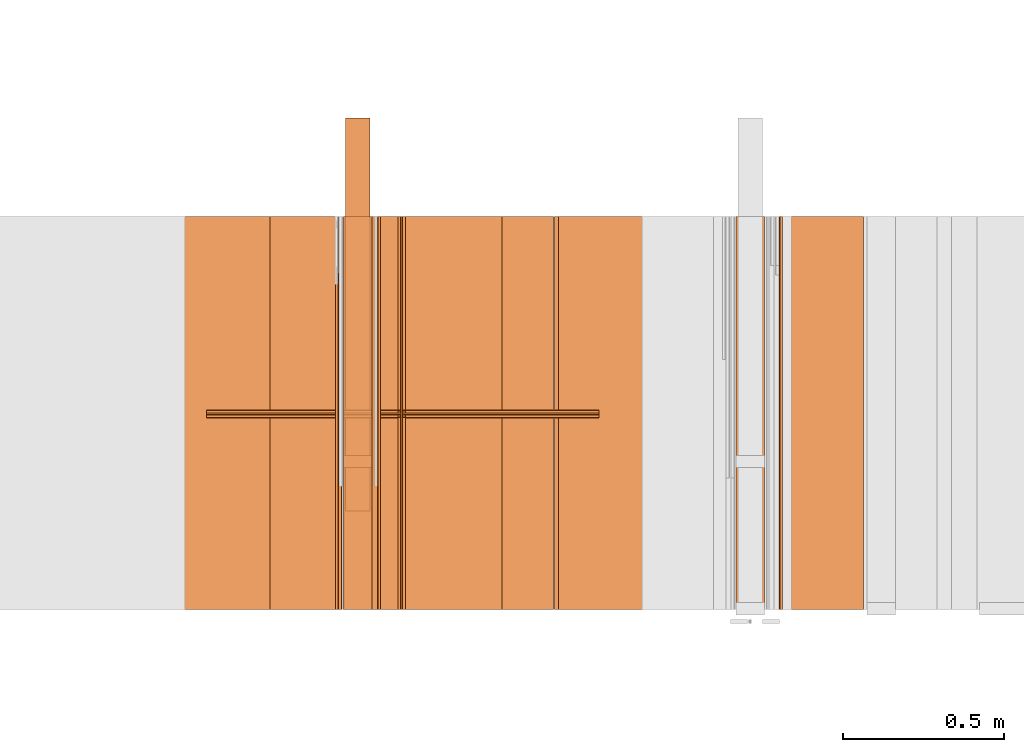
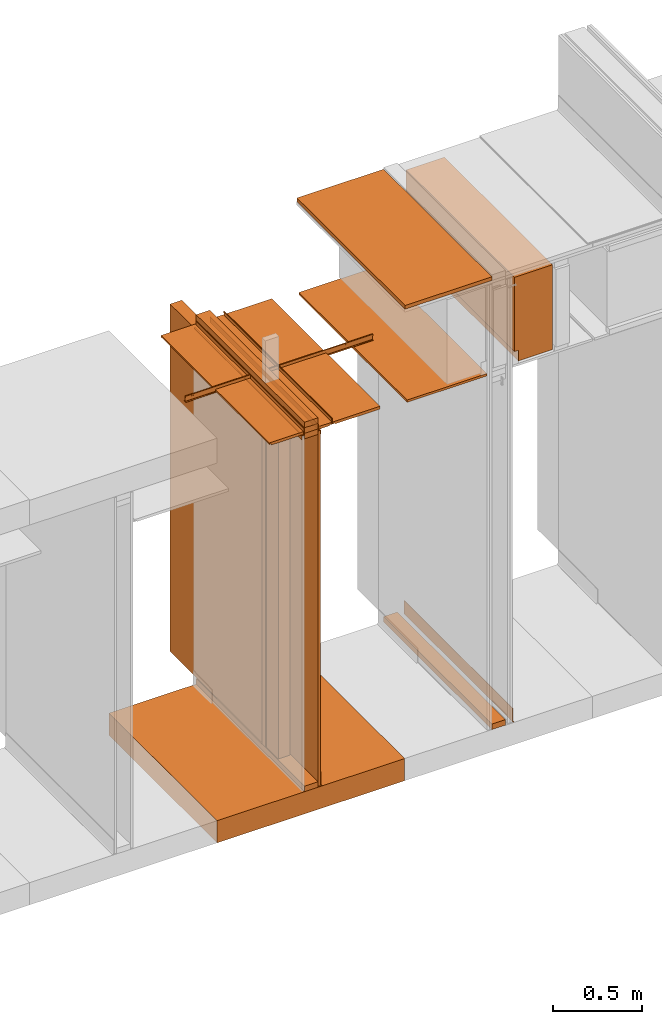
# One storey, part 34 of 64: 24 proxies.
"""IFC4 building model written with IfcOpenShell, lengths in feet."""

import ifcopenshell
import ifcopenshell.guid

model = None  # the IFC model being written
_history = None  # IfcOwnerHistory: only IFC2X3 demands one
_inside = {}  # id of a spatial element -> (the spatial element, [elements in it])
_under = {}  # id of a project, library or spatial element -> (it, [spatial elements below it])
_declared = {}  # id of a project -> (the project, [libraries it declares])
_typed = {}  # id of a type object -> (the type object, [elements of that type])
_made_of = {}  # id of a material, layer set ... -> (it, [elements and type objects made of it])


def new_model(schema):
    """Start an empty IFC model of exactly this schema.

    Asked for "IFC4X3", IfcOpenShell would pick the latest addendum, in which some entities
    have other attributes; the version numbers below select the first issue.
    IFC2X3 requires an IfcOwnerHistory on every rooted entity: one is made here for all.
    """
    global model, _history
    if schema == "IFC4X3":
        model = ifcopenshell.file(schema_version=(4, 3, 0, 0))
    else:
        model = ifcopenshell.file(schema=schema)
    _inside.clear()
    _under.clear()
    _declared.clear()
    _typed.clear()
    _made_of.clear()
    _history = None
    if model.schema == "IFC2X3":
        org = make("IfcOrganization", Name="unknown")
        user = make(
            "IfcPersonAndOrganization",
            ThePerson=make("IfcPerson", FamilyName="unknown"),
            TheOrganization=org,
        )
        app = make(
            "IfcApplication",
            ApplicationDeveloper=org,
            Version="unknown",
            ApplicationFullName="unknown",
            ApplicationIdentifier="unknown",
        )
        _history = make(
            "IfcOwnerHistory",
            OwningUser=user,
            OwningApplication=app,
            ChangeAction="ADDED",
            CreationDate=0,
        )
    return model


def make(cls, **values):
    """One entity of the class cls with the attributes given. An attribute that is None is left unset."""
    return model.create_entity(
        cls, **{name: value for name, value in values.items() if value is not None}
    )


def entity(cls, *values):
    """Any entity or typed value of the class cls, its attributes in the order of the schema. None: left unset."""
    e = model.create_entity(cls)
    for i, value in enumerate(values):
        if value is not None:
            e[i] = value
    return e


def rooted(cls, **values):
    """An entity with a GlobalId (a new one), such as an element, a storey or a relation."""
    return make(cls, GlobalId=ifcopenshell.guid.new(), OwnerHistory=_history, **values)


def si_unit(unit_type, name, prefix=None):
    """IfcSIUnit, for example si_unit("LENGTHUNIT", "METRE", prefix="MILLI")."""
    return make("IfcSIUnit", UnitType=unit_type, Prefix=prefix, Name=name)


def converted_unit(unit_type, name, factor, base, dimensions=None, offset=None):
    """IfcConversionBasedUnit, such as the inch: factor (a typed value) times the base unit."""
    return make(
        "IfcConversionBasedUnit"
        if offset is None
        else "IfcConversionBasedUnitWithOffset",
        ConversionOffset=offset,
        Dimensions=None
        if dimensions is None
        else entity("IfcDimensionalExponents", *dimensions),
        UnitType=unit_type,
        Name=name,
        ConversionFactor=make(
            "IfcMeasureWithUnit", ValueComponent=factor, UnitComponent=base
        ),
    )


def assignment(units):
    """IfcUnitAssignment: the units of a project."""
    return None if units is None else make("IfcUnitAssignment", Units=units)


def point(xyz):
    """IfcCartesianPoint."""
    return None if xyz is None else make("IfcCartesianPoint", Coordinates=xyz)


def direction(xyz):
    """IfcDirection."""
    return None if xyz is None else make("IfcDirection", DirectionRatios=xyz)


def frame(location, z_axis=None, x_axis=None):
    """IfcAxis2Placement3D, a coordinate frame: its origin and axes. An axis left out is left unset."""
    return make(
        "IfcAxis2Placement3D",
        Location=point(location),
        Axis=direction(z_axis),
        RefDirection=direction(x_axis),
    )


def frame_2d(location, x_axis=None):
    """IfcAxis2Placement2D, a coordinate frame in the plane: its origin and x axis."""
    return make(
        "IfcAxis2Placement2D", Location=point(location), RefDirection=direction(x_axis)
    )


def origin_with_axes():
    """The frame at (0, 0, 0) with the z axis (0, 0, 1) and the x axis (1, 0, 0) written out."""
    return frame((0.0, 0.0, 0.0), z_axis=(0.0, 0.0, 1.0), x_axis=(1.0, 0.0, 0.0))


def origin_2d_with_axis():
    """The frame at (0, 0) in the plane with the x axis (1, 0) written out."""
    return frame_2d((0.0, 0.0), x_axis=(1.0, 0.0))


def place(relative_to, where):
    """IfcLocalPlacement: puts the frame where relative to a parent placement (None: the world)."""
    return make(
        "IfcLocalPlacement", PlacementRelTo=relative_to, RelativePlacement=where
    )


def context(
    kind, dimensions, precision=None, world=None, true_north=None, identifier=None
):
    """IfcGeometricRepresentationContext, for example the 3D "Model" context."""
    return make(
        "IfcGeometricRepresentationContext",
        ContextIdentifier=identifier,
        ContextType=kind,
        CoordinateSpaceDimension=dimensions,
        Precision=precision,
        WorldCoordinateSystem=world,
        TrueNorth=true_north,
    )


def subcontext(parent, identifier, kind, view, scale=None):
    """IfcGeometricRepresentationSubContext, for example "Body" below "Model"."""
    return make(
        "IfcGeometricRepresentationSubContext",
        ContextIdentifier=identifier,
        ContextType=kind,
        ParentContext=parent,
        TargetScale=scale,
        TargetView=view,
    )


def project(units=None, contexts=None):
    """IfcProject with its units and contexts."""
    return rooted(
        "IfcProject",
        Name="project",
        RepresentationContexts=contexts,
        UnitsInContext=assignment(units),
    )


def spatial(cls, under=None, at=None, **own):
    """A site, building, storey or space (cls), placed at a placement, below another one or the project."""
    s = rooted(cls, ObjectPlacement=at, **own)
    if under is not None:
        _under.setdefault(under.id(), (under, []))[1].append(s)
    return s


def polyline(points):
    """IfcPolyline through the points."""
    return make("IfcPolyline", Points=[point(p) for p in points])


def point_list(points):
    """IfcCartesianPointList2D or 3D."""
    cls = (
        "IfcCartesianPointList2D" if len(points[0]) == 2 else "IfcCartesianPointList3D"
    )
    return make(cls, CoordList=points)


def line(*indices):
    """IfcLineIndex: a straight run through numbered points of an indexed curve."""
    return model.create_entity("IfcLineIndex", indices)


def indexed_curve(points, segments=None, self_intersect=None):
    """IfcIndexedPolyCurve: lines and arcs through numbered points (the first is 1)."""
    return make(
        "IfcIndexedPolyCurve",
        Points=point_list(points),
        Segments=segments,
        SelfIntersect=self_intersect,
    )


def outline(outer, holes=None, kind="AREA"):
    """IfcArbitraryClosedProfileDef: a profile drawn as a closed curve; with holes, ...WithVoids."""
    if holes is None:
        return make("IfcArbitraryClosedProfileDef", ProfileType=kind, OuterCurve=outer)
    return make(
        "IfcArbitraryProfileDefWithVoids",
        ProfileType=kind,
        OuterCurve=outer,
        InnerCurves=holes,
    )


def extrude(swept, where, along, depth):
    """IfcExtrudedAreaSolid: the profile swept, set in the frame where, extruded along a direction by depth."""
    return make(
        "IfcExtrudedAreaSolid",
        SweptArea=swept,
        Position=where,
        ExtrudedDirection=direction(along),
        Depth=depth,
    )


def shape(context_of_items, identifier, shape_type, items):
    """IfcShapeRepresentation: the items that make up one representation, for example the "Body"."""
    return make(
        "IfcShapeRepresentation",
        ContextOfItems=context_of_items,
        RepresentationIdentifier=identifier,
        RepresentationType=shape_type,
        Items=items,
    )


def material(Name=None, Category=None):
    """IfcMaterial."""
    return make("IfcMaterial", Name=Name, Category=Category)


def made_of(thing, what):
    """Note that an element or type object is made of a material, layer set ...; save() writes the relation."""
    if what is not None:
        _made_of.setdefault(what.id(), (what, []))[1].append(thing)
    return thing


def element(
    cls,
    number,
    at=None,
    inside=None,
    cuts=None,
    type_object=None,
    material=None,
    context=None,
    identifier="Body",
    shape_type=None,
    held_by="IfcProductDefinitionShape",
    body=None,
    shapes=None,
    **own,
):
    """One element of the class cls, such as IfcWall. Its Tag is "e" and its number.

    at: its placement. inside: the storey or other place that contains it. cuts: it is an
    opening in that element (IfcRelVoidsElement). A single representation is given by context,
    identifier, shape_type and body (its items); several are given by shapes. held_by: the class
    of the entity that holds the representations. save() writes the other relations.
    """
    e = rooted(cls, Tag="e%d" % number, ObjectPlacement=at, **own)
    if body is not None:
        shapes = [shape(context, identifier, shape_type, body)]
    if shapes is not None:
        e.Representation = make(held_by, Representations=shapes)
    if inside is not None:
        _inside.setdefault(inside.id(), (inside, []))[1].append(e)
    if cuts is not None:
        rooted(
            "IfcRelVoidsElement", RelatingBuildingElement=cuts, RelatedOpeningElement=e
        )
    if type_object is not None:
        _typed.setdefault(type_object.id(), (type_object, []))[1].append(e)
    return made_of(e, material)


def aggregate(whole, parts):
    """IfcRelAggregates: a whole, such as a stair, and the parts it consists of."""
    return rooted("IfcRelAggregates", RelatingObject=whole, RelatedObjects=parts)


def save(model, path):
    """Write the relations noted so far, then the file.

    IfcRelAggregates (storeys below a building ...), IfcRelContainedInSpatialStructure (elements
    in a storey), IfcRelDefinesByType, IfcRelAssociatesMaterial and IfcRelDeclares: one each for
    every whole, place, type object, material and project.
    """
    for whole, parts in _under.values():
        aggregate(whole, parts)
    for where, things in _inside.values():
        rooted(
            "IfcRelContainedInSpatialStructure",
            RelatedElements=things,
            RelatingStructure=where,
        )
    for kind, things in _typed.values():
        rooted("IfcRelDefinesByType", RelatedObjects=things, RelatingType=kind)
    for what, things in _made_of.values():
        rooted("IfcRelAssociatesMaterial", RelatedObjects=things, RelatingMaterial=what)
    for by, libraries in _declared.values():
        rooted("IfcRelDeclares", RelatingContext=by, RelatedDefinitions=libraries)
    model.write(path)


model = new_model("IFC4")

# Units and contexts
model_context_1 = context("Model", 3, precision=1e-05, world=origin_with_axes())
plan_context = context("Plan", 2, precision=1e-05, world=origin_2d_with_axis())
model_context_2 = context("Model", 3, precision=1e-05, world=origin_with_axes())
context_of_model_1 = context(None, 3, precision=1e-05, world=origin_with_axes())
context_of_model_2 = context(None, 3, precision=1e-05, world=origin_with_axes())
body_context = subcontext(model_context_2, "Body", "Model", "MODEL_VIEW")
ifc_project = project(units=[converted_unit("PLANEANGLEUNIT", "degree", entity("IfcReal", 0.0174532925199433), si_unit("PLANEANGLEUNIT", "RADIAN"), dimensions=[0, 0, 0, 0, 0, 0, 0]), converted_unit("AREAUNIT", "square foot", entity("IfcReal", 0.09290304), si_unit("AREAUNIT", "SQUARE_METRE"), dimensions=[2, 0, 0, 0, 0, 0, 0]), converted_unit("LENGTHUNIT", "foot", entity("IfcReal", 0.3048), si_unit("LENGTHUNIT", "METRE"), dimensions=[1, 0, 0, 0, 0, 0, 0]), converted_unit("VOLUMEUNIT", "cubic foot", entity("IfcReal", 0.0283168467116885), si_unit("VOLUMEUNIT", "CUBIC_METRE"), dimensions=[3, 0, 0, 0, 0, 0, 0])], contexts=[model_context_1, plan_context, context_of_model_1, context_of_model_2])

# Site, building, storey
site_placement = place(None, origin_with_axes())
site = spatial("IfcSite", under=ifc_project, at=site_placement)
building_placement = place(site_placement, origin_with_axes())
building = spatial("IfcBuilding", under=site, at=building_placement, Name="Building")
storey_placement = place(building_placement, origin_with_axes())
storey = spatial("IfcBuildingStorey", under=building, at=storey_placement, Name="Storey")

# Proxies
proxy_1_placement = place(storey_placement, frame((1383.04162213183, 5.99999987860051, 0.0), z_axis=(4.37113882867379e-08, -0.999999999999999, -8.51092183247426e-15), x_axis=(1.94707183709394e-07, 0.0, 0.999999999999981)))
element("IfcBuildingElementProxy", 1, at=proxy_1_placement, inside=storey, Name="Generic Models 13:Generic Models 1", PredefinedType="COMPLEX", context=body_context, shape_type="SweptSolid", body=[
    extrude(outline(polyline([(-0.0625000007724355, -0.145833333098669), (0.0625000007724355, -0.145833333098669), (0.062500006883476, 0.145833333098669), (-0.0625000007724355, 0.145833333098669), (-0.0625000007724355, -0.145833333098669)])), frame((0.0625000313276381, -0.145833320876588, -4.08491298529716e-07), z_axis=(-1.6389038902582e-14, 1.19209246918217e-07, -1.0), x_axis=(1.0, 1.94707183709397e-07, 0.0)), (5.40078315403036e-10, -5.71617336797559e-11, -1.0), 4.00000000752362),
])
proxy_2_placement = place(storey_placement, frame((1379.04530122211, 5.99999987860051, 7.9530516634463), z_axis=(4.37113882867379e-08, -0.999999999999999, -8.51092183247426e-15), x_axis=(1.94707183709394e-07, 0.0, 0.999999999999981)))
element("IfcBuildingElementProxy", 2, at=proxy_2_placement, inside=storey, Name="Generic Models 48:Generic Models 1", PredefinedType="COMPLEX", context=body_context, shape_type="SweptSolid", body=[
    extrude(outline(polyline([(-0.145833333098669, -0.0625000007724355), (0.145833333098669, -0.0625000007724355), (0.145833333098669, 0.0625000007724355), (-0.145833333098669, 0.062500006883476), (-0.145833333098669, -0.0625000007724355)])), frame((0.0625000313276381, -0.145833320876588, -1.73846880315148e-08), z_axis=(-3.2778077805164e-14, 1.19209289550781e-07, -1.0), x_axis=(-1.94707197920252e-07, 1.0, 1.19209289550781e-07)), (5.72196491577248e-11, 5.40068767485025e-10, -1.0), 4.00000000752362),
])
ifc_material_1 = material(Name="STRUCTURAL FLOOR", Category="concrete")
proxy_3_placement = place(storey_placement, frame((1377.1823072058, 5.99999987860051, -0.500000006179484), z_axis=(4.37113882867379e-08, -0.999999999999999, -8.51092183247426e-15), x_axis=(1.94707183709394e-07, 0.0, 0.999999999999981)))
element("IfcBuildingElementProxy", 3, at=proxy_3_placement, inside=storey, material=ifc_material_1, Name="Generic Models 561:Generic Models 1", PredefinedType="COMPLEX", context=body_context, shape_type="SweptSolid", body=[
    extrude(outline(polyline([(-0.250000003089742, -2.00000002471794), (0.250000003089742, -2.00000002471794), (0.250000003089742, 2.00000002471794), (-0.250000003089742, 2.00000002471794), (-0.250000003089742, -2.00000002471794)])), frame((0.250000394196335, -2.00000002471794, -6.29525198374314e-07), z_axis=(0.0, 1.19209289550781e-07, -1.0), x_axis=(1.0, 1.94707183709397e-07, 0.0)), (4.23038687413779e-10, -9.26340160134487e-09, -1.0), 4.00000000752362),
])
proxy_4_placement = place(storey_placement, frame((1383.52341539278, 5.99999987860051, 8.1138363660477), z_axis=(4.37113882867379e-08, -0.999999999999999, -8.51092183247426e-15), x_axis=(1.94707183709394e-07, 0.0, 0.999999999999981)))
element("IfcBuildingElementProxy", 4, at=proxy_4_placement, inside=storey, Name="Generic Models 21:Generic Models 1", PredefinedType="COMPLEX", context=body_context, shape_type="SweptSolid", body=[
    extrude(outline(polyline([(-0.298457181086065, -1.194856748024), (0.516202525673263, -1.194856748024), (0.516202476784939, 0.717593723629403), (-0.217745344587198, 0.717593674741079), (-0.217745344587198, 0.477263171059566), (-0.298457278862713, 0.477263171059566), (-0.298457181086065, -1.194856748024)])), frame((0.717593723629403, -0.298457107753578, -3.55788801744834e-08), z_axis=(-3.2888513960827e-14, 1.19209303761636e-07, -1.0), x_axis=(2.4004290821722e-07, -1.0, -1.19209289550781e-07)), (3.29755756034444e-09, 5.68858027349961e-09, -1.0), 4.00000000752362),
])
ifc_material_2 = material(Name="WALL BASE AS SCHEDULED")
proxy_5_placement = place(storey_placement, frame((1383.47916089957, 5.99999987860051, 0.0), z_axis=(4.37113882867379e-08, -0.999999999999999, -8.51092183247426e-15), x_axis=(1.94707183709394e-07, 0.0, 0.999999999999981)))
element("IfcBuildingElementProxy", 5, at=proxy_5_placement, inside=storey, material=ifc_material_2, Name="Generic Models 228:Generic Models 1", PredefinedType="COMPLEX", context=body_context, shape_type="SweptSolid", body=[
    extrude(outline(polyline([(0.220647404395689, -6.29889841073551e-10), (0.220442880091705, 0.00356434038693569), (0.218163535311779, 0.00828269806756513), (0.213215401361934, 0.0100073574497083), (-0.0621307594823869, -0.00579188951520919), (-0.0746566692264531, -0.00486853115414599), (-0.0865167811063174, -0.000734690297517212), (-0.0969028489033538, 0.00632791332301642), (-0.105107085793976, 0.0158379745383666), (-0.113815000754955, 0.0101214184931765), (-0.103834498272793, -0.00144763436187376), (-0.0911997814523423, -0.0100393357608477), (-0.0767718836802041, -0.015068177458906), (-0.0615340408201762, -0.0161914508716445), (0.220647404395689, -6.29889841073551e-10)])), frame((0.113048297389755, -0.0126398416918035, -1.50679009951663e-09), z_axis=(-3.19906929180554e-14, 1.19209282445354e-07, -1.0), x_axis=(0.998357832431793, 0.0572855435311794, 6.82893697145914e-09)), (1.19532195252958e-09, -3.91987414749551e-11, -1.0), 4.00000000752362),
])
proxy_6_placement = place(storey_placement, frame((1379.04530122211, 5.99999987860051, 8.2030516909802), z_axis=(4.37113882867379e-08, -0.999999999999999, -8.51092183247426e-15), x_axis=(1.94707183709394e-07, 0.0, 0.999999999999981)))
element("IfcBuildingElementProxy", 6, at=proxy_6_placement, inside=storey, Name="Generic Models 250:Generic Models 1", PredefinedType="COMPLEX", context=body_context, shape_type="SweptSolid", body=[
    extrude(outline(polyline([(-0.062500006883476, -0.145833320876588), (0.0625000007724355, -0.145833320876588), (0.0625000007724355, 0.14583334532075), (-0.0625000007724355, 0.14583334532075), (-0.062500006883476, -0.145833320876588)])), frame((0.0625000313276381, -0.145833333098669, -1.73846880315148e-08), z_axis=(-3.2778077805164e-14, 1.19209289550781e-07, -1.0), x_axis=(-1.0, -1.9555329799914e-07, 0.0)), (-5.09230324574617e-10, 4.3999508897441e-11, -1.0), 4.00000000752362),
])
proxy_7_placement = place(storey_placement, frame((1381.23439678683, 5.99999987860051, 8.01041683187009), z_axis=(4.37113882867379e-08, -0.999999999999999, -8.51092183247426e-15), x_axis=(1.94707183709394e-07, 0.0, 0.999999999999981)))
element("IfcBuildingElementProxy", 7, at=proxy_7_placement, inside=storey, Name="Generic Models 372:Generic Models 1", PredefinedType="COMPLEX", context=body_context, shape_type="SweptSolid", body=[
    extrude(outline(polyline([(-0.0260416674977682, -0.851562544899037), (0.0260416674977682, -0.851562544899037), (0.0260416644422479, 0.851562544899037), (-0.0260416674977682, 0.851562544899037), (-0.0260416674977682, -0.851562544899037)])), frame((0.0260418324958621, -0.851562544899037, -1.01514165985469e-07), z_axis=(0.0, 1.19209289550781e-07, -1.0), x_axis=(1.0, 1.94707169498542e-07, -8.51092267950722e-15)), (-2.01841821034776e-10, 4.27915214373797e-09, -1.0), 4.00000000752362),
])
proxy_8_placement = place(storey_placement, frame((1381.1927454991, 5.99999987860051, 10.1250003329099), z_axis=(4.37113882867379e-08, -0.999999999999999, -8.51092183247426e-15), x_axis=(1.94707183709394e-07, 0.0, 0.999999999999981)))
element("IfcBuildingElementProxy", 8, at=proxy_8_placement, inside=storey, Name="Generic Models 385:Generic Models 1", PredefinedType="COMPLEX", context=body_context, shape_type="SweptSolid", body=[
    extrude(outline(polyline([(-0.0416666692186372, -0.92447918700421), (0.0416666692186372, -0.92447918700421), (0.0416666692186372, 0.92447918700421), (-0.0416666692186372, 0.92447918700421), (-0.0416666692186372, -0.92447918700421)])), frame((0.0416668494943324, -0.92447918700421, -1.10206507087256e-07), z_axis=(0.0, 1.19209289550781e-07, -1.0), x_axis=(1.0, 1.94707169498542e-07, -8.51092267950722e-15)), (6.82104650540083e-11, 5.03972774623662e-09, -1.0), 4.00000000752362),
])
proxy_9_placement = place(storey_placement, frame((1379.06612686598, 2.99999993930026, 0.125000001544871), z_axis=(0.0, 0.0, 1.0), x_axis=(-1.62920684942944e-07, 0.999999999999987, 0.0)))
element("IfcBuildingElementProxy", 9, at=proxy_9_placement, inside=storey, Name="Generic Models 386:Generic Models 1", PredefinedType="COMPLEX", context=body_context, shape_type="SweptSolid", body=[
    extrude(outline(polyline([(-2.00000002471794, -0.125000001544871), (2.00000002471794, -0.125000001544871), (2.00000002471794, 0.125000001544871), (-2.00000002471794, 0.125000001544871), (-2.00000002471794, -0.125000001544871)])), frame((2.00000002471794, -0.125000001544871, 0.0), z_axis=(0.0, 0.0, -1.0), x_axis=(-1.0, 0.0, 0.0)), (0.0, 0.0, -1.0), 7.82805155106246),
])
proxy_10_placement = place(storey_placement, frame((1379.04530122211, 5.99999987860051, 0.0), z_axis=(4.37113882867379e-08, -0.999999999999999, -8.51092183247426e-15), x_axis=(1.94707183709394e-07, 0.0, 0.999999999999981)))
element("IfcBuildingElementProxy", 10, at=proxy_10_placement, inside=storey, Name="Generic Models 412:Generic Models 1", PredefinedType="COMPLEX", context=body_context, shape_type="SweptSolid", body=[
    extrude(outline(polyline([(-0.0625000007724355, -0.145833333098669), (0.0625000007724355, -0.145833333098669), (0.062500006883476, 0.145833333098669), (-0.0625000007724355, 0.145833333098669), (-0.0625000007724355, -0.145833333098669)])), frame((0.0625000313276381, -0.145833320876588, -1.73846880315148e-08), z_axis=(-3.2778077805164e-14, 1.19209289550781e-07, -1.0), x_axis=(1.0, 1.94707183709397e-07, -8.51092267950722e-15)), (5.40069822196898e-10, -5.72200134496548e-11, -1.0), 4.00000000752362),
])
proxy_11_placement = place(storey_placement, frame((1379.38912459246, 5.99999987860051, 0.0), z_axis=(4.37113882867379e-08, -0.999999999999999, -8.51092183247426e-15), x_axis=(1.94707183709394e-07, 0.0, 0.999999999999981)))
element("IfcBuildingElementProxy", 11, at=proxy_11_placement, inside=storey, material=ifc_material_2, Name="Generic Models 415:Generic Models 1", PredefinedType="COMPLEX", context=body_context, shape_type="SweptSolid", body=[
    extrude(outline(polyline([(-0.213438576561572, 0.00222319596675603), (0.0623605162726613, 0.00222319596675603), (0.0748129590876459, 0.000583802452912857), (0.0864167861503566, -0.00422266024724627), (0.0963812104849208, -0.0118686360175039), (0.104027191602339, -0.0218330626437084), (0.113048285167674, -0.0166247312830189), (0.103746902618039, -0.00450293968304542), (0.0916251159832859, 0.00479843828330926), (0.0775089912761853, 0.0106455295913782), (0.0623605162726613, 0.0126398630804453), (-0.220285068581423, 0.0126398630804453), (-0.220285068581423, 0.0090696595320747), (-0.21827976730239, 0.00422847872169742), (-0.213438576561572, 0.00222319596675603)])), frame((0.113048285167674, -0.0126398409279234, -3.92613419174284e-07), z_axis=(8.52252906376368e-14, 1.19209985882662e-07, -1.0), x_axis=(-1.0, -1.93878832988048e-07, 0.0)), (6.12672523825353e-10, 1.03401905093836e-10, -1.0), 4.00000000752362),
])
proxy_12_placement = place(storey_placement, frame((1379.04530122211, 3.44270835398376, 0.125000001544871), z_axis=(0.0, 0.0, 1.0), x_axis=(1.0, 0.0, 0.0)))
element("IfcBuildingElementProxy", 12, at=proxy_12_placement, inside=storey, Name="Generic Models 419:Generic Models 65", PredefinedType="COMPLEX", context=body_context, shape_type="SweptSolid", body=[
    extrude(outline(polyline([(-0.145833333098669, -0.0625000007724355), (0.145833333098669, -0.0625000007724355), (0.145833333098669, 0.0625000007724355), (-0.145833333098669, 0.0625000007724355), (-0.145833333098669, -0.0625000007724355)])), frame((0.145833333098669, 0.0625000007724355, 0.0), z_axis=(0.0, 0.0, -1.0), x_axis=(-1.0, 0.0, 0.0)), (0.0, 0.0, -1.0), 7.82805155106246),
])
ifc_material_3 = material(Category="sand")
proxy_13_placement = place(storey_placement, frame((1379.33696035951, 5.99999987860051, 0.0208333330815585), z_axis=(4.37113882867379e-08, -0.999999999999999, -8.51092183247426e-15), x_axis=(1.94707183709394e-07, 0.0, 0.999999999999981)))
element("IfcBuildingElementProxy", 13, at=proxy_13_placement, inside=storey, material=ifc_material_3, Name="Generic Models 432:Generic Models 1", PredefinedType="COMPLEX", context=body_context, shape_type="SweptSolid", body=[
    extrude(outline(polyline([(-4.00429713757332, -0.0260416674977682), (4.00429713757332, -0.0260416674977682), (4.00429713757332, 0.0260416674977682), (-4.00429713757332, 0.0260416674977682), (-4.00429713757332, -0.0260416674977682)])), frame((4.00429713757332, -0.0260408883401024, -3.94211021364806e-07), z_axis=(-2.90081645498968e-14, 1.19209147442234e-07, -1.0), x_axis=(1.0, 1.94707183709397e-07, -5.82168836318138e-15)), (-1.26761612317949e-09, 8.30831445308711e-11, -1.0), 4.00000000752362),
])
proxy_14_placement = place(storey_placement, frame((1379.59768140097, 5.99999987860051, 8.07805167721325), z_axis=(4.37113882867379e-08, -0.999999999999999, -8.51092183247426e-15), x_axis=(1.94707183709394e-07, 0.0, 0.999999999999981)))
element("IfcBuildingElementProxy", 14, at=proxy_14_placement, inside=storey, Name="Generic Models 565:Generic Models 1", PredefinedType="COMPLEX", context=body_context, shape_type="SweptSolid", body=[
    extrude(outline(indexed_curve([(0.0296970291596072, 0.00584526601665485), (0.0310626083843195, 0.00603154810081942), (0.0626632511087759, 0.0014601720208571), (0.0643079704421712, 0.000482393316240135), (0.0647795777719008, -0.00137198206741275), (0.0625126995146275, -0.0170422039603389), (0.0615349085879295, -0.0186869355158152), (0.0596805194544354, -0.0191585306234638), (0.0280798858965397, -0.0145871407936603), (0.0268230801374893, -0.0140215089945538), (0.0260570398201858, -0.0128758294517639), (0.0234390624243952, -0.00470634757631563), (-0.0547061508076554, 0.00659821266577313), (-0.0569313823238132, 0.00603231159894387), (-0.0581047204359779, 0.00405863991980086), (-0.0618188275302958, -0.0216159434852207), (-0.0612498224368246, -0.0282138154604851), (-0.063385453876939, -0.0304752946134627), (-0.0653873390843236, -0.0280945523937778), (-0.0547449498038905, 0.0454730346916229), (-0.052150489219765, 0.0471888804255821), (-0.0507432907536196, 0.0444148408048578), (-0.0531587436834345, 0.0382487337029199), (-0.0568728507777524, 0.0125741541172986), (-0.0563069378707822, 0.0103488813516173), (-0.0543332734484998, 0.00917554858661308), (0.0238125019992782, -0.00212908727960206), (0.0286377505631506, 0.00496365217335542), (0.0301359515891379, 0.00484996925051913), (0.0636623756779148, 1.22221276552383e-08), (0.0610525213827298, -0.0180413728345215), (0.0275254770233406, -0.0131913027518338), (0.024430948466043, -0.0035348496512263)], segments=[line(7, 6), line(6, 5), line(5, 4), line(4, 3), line(3, 2), line(2, 1), line(1, 28), line(28, 27), line(27, 26), line(26, 25), line(25, 24), line(24, 23), line(23, 22), line(22, 21), line(21, 20), line(20, 19), line(19, 18), line(18, 17), line(17, 16), line(16, 15), line(15, 14), line(14, 13), line(13, 12), line(12, 11), line(11, 10), line(10, 9), line(9, 8), line(8, 7)], self_intersect=False), holes=[indexed_curve([(0.0296970291596072, 0.00584526601665485), (0.0310626083843195, 0.00603154810081942), (0.0626632511087759, 0.0014601720208571), (0.0643079704421712, 0.000482393316240135), (0.0647795777719008, -0.00137198206741275), (0.0625126995146275, -0.0170422039603389), (0.0615349085879295, -0.0186869355158152), (0.0596805194544354, -0.0191585306234638), (0.0280798858965397, -0.0145871407936603), (0.0268230801374893, -0.0140215089945538), (0.0260570398201858, -0.0128758294517639), (0.0234390624243952, -0.00470634757631563), (-0.0547061508076554, 0.00659821266577313), (-0.0569313823238132, 0.00603231159894387), (-0.0581047204359779, 0.00405863991980086), (-0.0618188275302958, -0.0216159434852207), (-0.0612498224368246, -0.0282138154604851), (-0.063385453876939, -0.0304752946134627), (-0.0653873390843236, -0.0280945523937778), (-0.0547449498038905, 0.0454730346916229), (-0.052150489219765, 0.0471888804255821), (-0.0507432907536196, 0.0444148408048578), (-0.0531587436834345, 0.0382487337029199), (-0.0568728507777524, 0.0125741541172986), (-0.0563069378707822, 0.0103488813516173), (-0.0543332734484998, 0.00917554858661308), (0.0238125019992782, -0.00212908727960206), (0.0286377505631506, 0.00496365217335542), (0.0301359515891379, 0.00484996925051913), (0.0636623756779148, 1.22221276552383e-08), (0.0610525213827298, -0.0180413728345215), (0.0275254770233406, -0.0131913027518338), (0.024430948466043, -0.0035348496512263)], segments=[line(31, 32), line(32, 33), line(33, 29), line(29, 30), line(30, 31)], self_intersect=False)]), frame((0.0606913649992836, -0.0392497557501389, -3.95785544903478e-07), z_axis=(4.56824942457468e-12, 1.19214490723607e-07, -1.0), x_axis=(0.989697992801666, -0.143170446157455, -1.70668190691003e-08)), (-5.47911105375221e-10, -1.58496715751966e-10, -1.0), 4.00000000752362),
])
ifc_material_4 = material(Name="J BEAD DRYWALL TRIM", Category="poche")
proxy_15_placement = place(storey_placement, frame((1379.33335592115, 5.99999987860051, 7.94737514235529), z_axis=(4.37113882867379e-08, -0.999999999999999, -8.51092183247426e-15), x_axis=(1.94707183709394e-07, 0.0, 0.999999999999981)))
element("IfcBuildingElementProxy", 15, at=proxy_15_placement, inside=storey, material=ifc_material_4, Name="Generic Models 568:Generic Models 1", PredefinedType="COMPLEX", context=body_context, shape_type="SweptSolid", body=[
    extrude(outline(polyline([(-0.0344678146026422, -0.0297083376400818), (0.0524882097628329, -0.0297083376400818), (0.0524882097628329, -0.0260416705532884), (-0.0312586138978248, -0.0260416705532884), (-0.0312586138978248, 0.0260416644422479), (0.0131548778948391, 0.0260416644422479), (0.0133215427750678, 0.0297083315290413), (-0.0344678146026422, 0.0297083315290413), (-0.0344678146026422, -0.0297083376400818)])), frame((0.0524882158738735, -0.0297083193069603, -3.94648117043793e-07), z_axis=(-2.40435752904555e-12, 1.19208344528943e-07, -1.0), x_axis=(-1.0, -2.1083209844619e-07, 0.0)), (3.81318622511007e-11, 3.32015331894198e-10, -1.0), 4.00000000752362),
])
proxy_16_placement = place(storey_placement, frame((1379.04530122211, 5.99999987860051, 8.07805167721325), z_axis=(4.37113882867379e-08, -0.999999999999999, -8.51092183247426e-15), x_axis=(1.94707183709394e-07, 0.0, 0.999999999999981)))
element("IfcBuildingElementProxy", 16, at=proxy_16_placement, inside=storey, Name="Generic Models 569:Generic Models 1", PredefinedType="COMPLEX", context=body_context, shape_type="SweptSolid", body=[
    extrude(outline(polyline([(-0.145833333098669, -0.0625000007724355), (0.145833333098669, -0.0625000007724355), (0.145833333098669, 0.0625000007724355), (-0.145833333098669, 0.062500006883476), (-0.145833333098669, -0.0625000007724355)])), frame((0.0625000313276381, -0.145833320876588, -1.73846880315148e-08), z_axis=(-3.2778077805164e-14, 1.19209289550781e-07, -1.0), x_axis=(-1.94707197920252e-07, 1.0, 1.19209289550781e-07)), (5.72196491577248e-11, 5.40068767485025e-10, -1.0), 4.00000000752362),
])
ifc_material_5 = material(Name="ACOUSTICAL SEALANT", Category="sealant")
proxy_17_placement = place(storey_placement, frame((1378.99323711245, 5.99999987860051, 8.03645827325936), z_axis=(4.37113882867379e-08, -0.999999999999999, -8.51092183247426e-15), x_axis=(1.94707183709394e-07, 0.0, 0.999999999999981)))
element("IfcBuildingElementProxy", 17, at=proxy_17_placement, inside=storey, material=ifc_material_5, Name="Generic Models 570:Generic Models 1", PredefinedType="COMPLEX", context=body_context, shape_type="SweptSolid", body=[
    extrude(outline(polyline([(0.0200664036078599, 9.49803628864403e-10), (-0.00664321054873152, 0.0162221848221589), (-0.0159632111471782, 0.00969531626276809), (-0.0174579991570373, -0.00158422404265867), (0.00925161041627367, -0.0178064079099675), (0.010746400717773, -0.00652686703163065), (0.0200664036078599, 9.49803628864403e-10)])), frame((0.0104166703601796, -0.0171509010379943, -2.04454727426466e-09), z_axis=(-1.8821786983798e-14, 1.19209317972491e-07, -1.0), x_axis=(0.519109785556793, 0.854707658290863, 1.01889078507611e-07)), (-8.89110868262932e-11, -1.99414706969492e-10, -1.0), 4.00000000752362),
])
ifc_material_6 = material(Name="CEILING TRACK AS SCHEDULED", Category="poche")
proxy_18_placement = place(storey_placement, frame((1379.33696035951, 5.99999987860051, 8.05729173925605), z_axis=(4.37113882867379e-08, -0.999999999999999, -8.51092183247426e-15), x_axis=(1.94707183709394e-07, 0.0, 0.999999999999981)))
element("IfcBuildingElementProxy", 18, at=proxy_18_placement, inside=storey, material=ifc_material_6, Name="Generic Models 572:Generic Models 1", PredefinedType="COMPLEX", context=body_context, shape_type="SweptSolid", body=[
    extrude(outline(polyline([(0.0867708292826423, -1.49860712203641e-09), (0.0849992875254217, 0.00489779119807591), (-0.0276499528076079, -0.03584767532904), (-0.0542230852769585, 0.037619220141781), (-0.0591208825860749, 0.0358476783845603), (-0.0307762053039834, -0.0425170113398569), (0.0867708292826423, -1.49860712203641e-09)])), frame((0.0434027852739875, -0.0295138812753472, -3.94624898521325e-07), z_axis=(0.0, 1.19209815352406e-07, -1.0), x_axis=(0.940376162528992, 0.340136259794235, 4.0547099899868e-08)), (-1.29517271907353e-10, -1.93627558431331e-10, -1.0), 4.00000000752362),
])
ifc_material_7 = material(Name="EXISTING ACOUSTICAL TILE", Category="poche")
proxy_19_placement = place(storey_placement, frame((1379.35648440063, 5.99999987860051, 8.06249971464863), z_axis=(4.37113882867379e-08, -0.999999999999999, -8.51092183247426e-15), x_axis=(1.94707183709394e-07, 0.0, 0.999999999999981)))
element("IfcBuildingElementProxy", 19, at=proxy_19_placement, inside=storey, material=ifc_material_7, Name="Generic Models 573:Generic Models 1", PredefinedType="COMPLEX", context=body_context, shape_type="SweptSolid", body=[
    extrude(outline(polyline([(0.0648316988364605, 1.52775748817601e-09), (0.056761642062445, 0.0265119334541046), (-0.164585280919012, 0.0383837571431176), (-0.167932627805731, -0.0240265457766263), (0.104485959635945, -0.0386375730999029), (0.10643857152365, -0.00223155797085189), (0.0648316988364605, 1.52775748817601e-09)])), frame((0.0295139240526308, -0.166404782122201, -4.1094360343887e-07), z_axis=(-6.03470832333253e-13, 1.19209332183345e-07, -1.0), x_axis=(-0.0535573028028011, -0.998564839363098, -1.19038290335993e-07)), (2.012843003385e-09, 2.74091055407766e-10, -1.0), 4.00000000752362),
])
proxy_20_placement = place(storey_placement, frame((1379.64473934624, 5.99999987860051, 8.06249971464863), z_axis=(4.37113882867379e-08, -0.999999999999999, -8.51092183247426e-15), x_axis=(1.94707183709394e-07, 0.0, 0.999999999999981)))
element("IfcBuildingElementProxy", 20, at=proxy_20_placement, inside=storey, material=ifc_material_7, Name="Generic Models 574:Generic Models 1", PredefinedType="COMPLEX", context=body_context, shape_type="SweptSolid", body=[
    extrude(outline(polyline([(-0.0329862356068581, -0.659830506470573), (0.0295137621100571, -0.659830506470573), (0.0295139515523131, 0.301973107136454), (0.00347228405454497, 0.311451502085671), (0.00347229322110574, 0.353118165193267), (-0.0329860400535616, 0.353118165193267), (-0.0329862356068581, -0.659830506470573)])), frame((0.0295139607188739, -0.353118165193267, -4.33201587754251e-07), z_axis=(4.87306592647507e-13, 1.19209303761636e-07, -1.0), x_axis=(-1.0, 0.0, 0.0)), (0.0, -3.01151925619081e-09, -1.0), 4.00000000752362),
])
proxy_21_placement = place(storey_placement, frame((1378.29477705668, 5.99999987860051, 8.06249971464863), z_axis=(4.37113882867379e-08, -0.999999999999999, -8.51092183247426e-15), x_axis=(1.94707183709394e-07, 0.0, 0.999999999999981)))
element("IfcBuildingElementProxy", 21, at=proxy_21_placement, inside=storey, material=ifc_material_7, Name="Generic Models 575:Generic Models 1", PredefinedType="COMPLEX", context=body_context, shape_type="SweptSolid", body=[
    extrude(outline(polyline([(0.210121185995462, 2.22077733135034e-09), (0.215847768730379, 0.0271148456558781), (0.257101349943266, 0.032967398324468), (0.25198037132347, 0.0690642910523052), (-0.471914592846798, -0.0336330739678595), (-0.463135765371673, -0.0955134549537512), (0.210121185995462, 2.22077733135034e-09)])), frame((0.0295139423857524, -0.259183112561233, -4.22003639382244e-07), z_axis=(0.0, 1.19209261129072e-07, -1.0), x_axis=(-0.140461504459381, 0.990086138248444, 1.18027550399802e-07)), (4.49586146089587e-09, -8.24930679321767e-10, -1.0), 4.00000000752362),
])
proxy_22_placement = place(storey_placement, frame((1378.98963267409, 5.99999987860051, 7.94737514235529), z_axis=(4.37113882867379e-08, -0.999999999999999, -8.51092183247426e-15), x_axis=(1.94707183709394e-07, 0.0, 0.999999999999981)))
element("IfcBuildingElementProxy", 22, at=proxy_22_placement, inside=storey, material=ifc_material_4, Name="Generic Models 582:Generic Models 1", PredefinedType="COMPLEX", context=body_context, shape_type="SweptSolid", body=[
    extrude(outline(polyline([(-0.034467811547122, -0.0297083376400818), (0.013321545830588, -0.0297083376400818), (0.0131548778948391, -0.0260416705532884), (-0.0312586108423046, -0.0260416705532884), (-0.0312586138978248, 0.0260416613867277), (0.0524882097628329, 0.0260416674977682), (0.0524882097628329, 0.0297083345845615), (-0.0344678146026422, 0.029708328473521), (-0.034467811547122, -0.0297083376400818)])), frame((0.0524882158738735, -0.0297083223624805, -3.54150945956249e-09), z_axis=(-5.78297379059088e-14, 1.19209275339927e-07, -1.0), x_axis=(-0.999999940395355, -2.55749000643846e-07, 1.52438283350376e-14)), (3.71754016459391e-10, -2.56443311030807e-10, -1.0), 4.00000000752362),
])
proxy_23_placement = place(storey_placement, frame((1378.96199864665, 5.99999987860051, 8.05729173925605), z_axis=(4.37113882867379e-08, -0.999999999999999, -8.51092183247426e-15), x_axis=(1.94707183709394e-07, 0.0, 0.999999999999981)))
element("IfcBuildingElementProxy", 23, at=proxy_23_placement, inside=storey, material=ifc_material_6, Name="Generic Models 588:Generic Models 1", PredefinedType="COMPLEX", context=body_context, shape_type="SweptSolid", body=[
    extrude(outline(polyline([(0.0851402753411628, 1.0642824475317e-15), (0.0866271281649121, 0.0049915956699942), (-0.0331710823603815, 0.0406761581611054), (-0.056960794761816, -0.0391893236704777), (-0.0519691990918218, -0.0406761795497472), (-0.0296663486806974, 0.0341977096673619), (0.0851402753411628, 1.0642824475317e-15)])), frame((0.0434027883295077, -0.0538194449398461, -6.41577925228204e-09), z_axis=(0.0, 1.19209261129072e-07, -1.0), x_axis=(0.958385765552521, -0.285476326942444, -3.4031454987371e-08)), (-4.20733725636779e-10, 1.42574785311211e-10, -1.0), 4.00000000752362),
])
proxy_24_placement = place(storey_placement, frame((1377.64737987769, 3.95033928978787, 8.07805167721325), z_axis=(0.999999999999928, 3.2584136988587e-07, -1.94707183709383e-07), x_axis=(1.94707183709394e-07, 0.0, 0.999999999999981)))
element("IfcBuildingElementProxy", 24, at=proxy_24_placement, inside=storey, Name="Generic Models 565:Generic Models 1", PredefinedType="COMPLEX", context=body_context, shape_type="SweptSolid", body=[
    extrude(outline(indexed_curve([(0.0296970291596072, 0.00584526601665485), (0.0310626083843195, 0.00603154810081942), (0.0626632511087759, 0.0014601720208571), (0.0643079704421712, 0.000482393316240135), (0.0647795777719008, -0.00137198206741275), (0.0625126995146275, -0.0170422039603389), (0.0615349085879295, -0.0186869355158152), (0.0596805194544354, -0.0191585306234638), (0.0280798858965397, -0.0145871407936603), (0.0268230801374893, -0.0140215089945538), (0.0260570398201858, -0.0128758294517639), (0.0234390624243952, -0.00470634757631563), (-0.0547061508076554, 0.00659821266577313), (-0.0569313823238132, 0.00603231159894387), (-0.0581047204359779, 0.00405863991980086), (-0.0618188275302958, -0.0216159434852207), (-0.0612498224368246, -0.0282138154604851), (-0.063385453876939, -0.0304752946134627), (-0.0653873390843236, -0.0280945523937778), (-0.0547449498038905, 0.0454730346916229), (-0.052150489219765, 0.0471888804255821), (-0.0507432907536196, 0.0444148408048578), (-0.0531587436834345, 0.0382487337029199), (-0.0568728507777524, 0.0125741541172986), (-0.0563069378707822, 0.0103488813516173), (-0.0543332734484998, 0.00917554858661308), (0.0238125019992782, -0.00212908727960206), (0.0286377505631506, 0.00496365217335542), (0.0301359515891379, 0.00484996925051913), (0.0636623756779148, 1.22221276552383e-08), (0.0610525213827298, -0.0180413728345215), (0.0275254770233406, -0.0131913027518338), (0.024430948466043, -0.0035348496512263)], segments=[line(7, 6), line(6, 5), line(5, 4), line(4, 3), line(3, 2), line(2, 1), line(1, 28), line(28, 27), line(27, 26), line(26, 25), line(25, 24), line(24, 23), line(23, 22), line(22, 21), line(21, 20), line(20, 19), line(19, 18), line(18, 17), line(17, 16), line(16, 15), line(15, 14), line(14, 13), line(13, 12), line(12, 11), line(11, 10), line(10, 9), line(9, 8), line(8, 7)], self_intersect=False), holes=[indexed_curve([(0.0296970291596072, 0.00584526601665485), (0.0310626083843195, 0.00603154810081942), (0.0626632511087759, 0.0014601720208571), (0.0643079704421712, 0.000482393316240135), (0.0647795777719008, -0.00137198206741275), (0.0625126995146275, -0.0170422039603389), (0.0615349085879295, -0.0186869355158152), (0.0596805194544354, -0.0191585306234638), (0.0280798858965397, -0.0145871407936603), (0.0268230801374893, -0.0140215089945538), (0.0260570398201858, -0.0128758294517639), (0.0234390624243952, -0.00470634757631563), (-0.0547061508076554, 0.00659821266577313), (-0.0569313823238132, 0.00603231159894387), (-0.0581047204359779, 0.00405863991980086), (-0.0618188275302958, -0.0216159434852207), (-0.0612498224368246, -0.0282138154604851), (-0.063385453876939, -0.0304752946134627), (-0.0653873390843236, -0.0280945523937778), (-0.0547449498038905, 0.0454730346916229), (-0.052150489219765, 0.0471888804255821), (-0.0507432907536196, 0.0444148408048578), (-0.0531587436834345, 0.0382487337029199), (-0.0568728507777524, 0.0125741541172986), (-0.0563069378707822, 0.0103488813516173), (-0.0543332734484998, 0.00917554858661308), (0.0238125019992782, -0.00212908727960206), (0.0286377505631506, 0.00496365217335542), (0.0301359515891379, 0.00484996925051913), (0.0636623756779148, 1.22221276552383e-08), (0.0610525213827298, -0.0180413728345215), (0.0275254770233406, -0.0131913027518338), (0.024430948466043, -0.0035348496512263)], segments=[line(31, 32), line(32, 33), line(33, 29), line(29, 30), line(30, 31)], self_intersect=False)]), frame((0.0606913649992836, -0.0392497557501389, -3.95785544903478e-07), z_axis=(4.56824942457468e-12, 1.19214490723607e-07, -1.0), x_axis=(0.989697992801666, -0.143170446157455, -1.70668190691003e-08)), (-5.47911105375221e-10, -1.58496715751966e-10, -1.0), 4.00000000752362),
])

save(model, "model.ifc")
